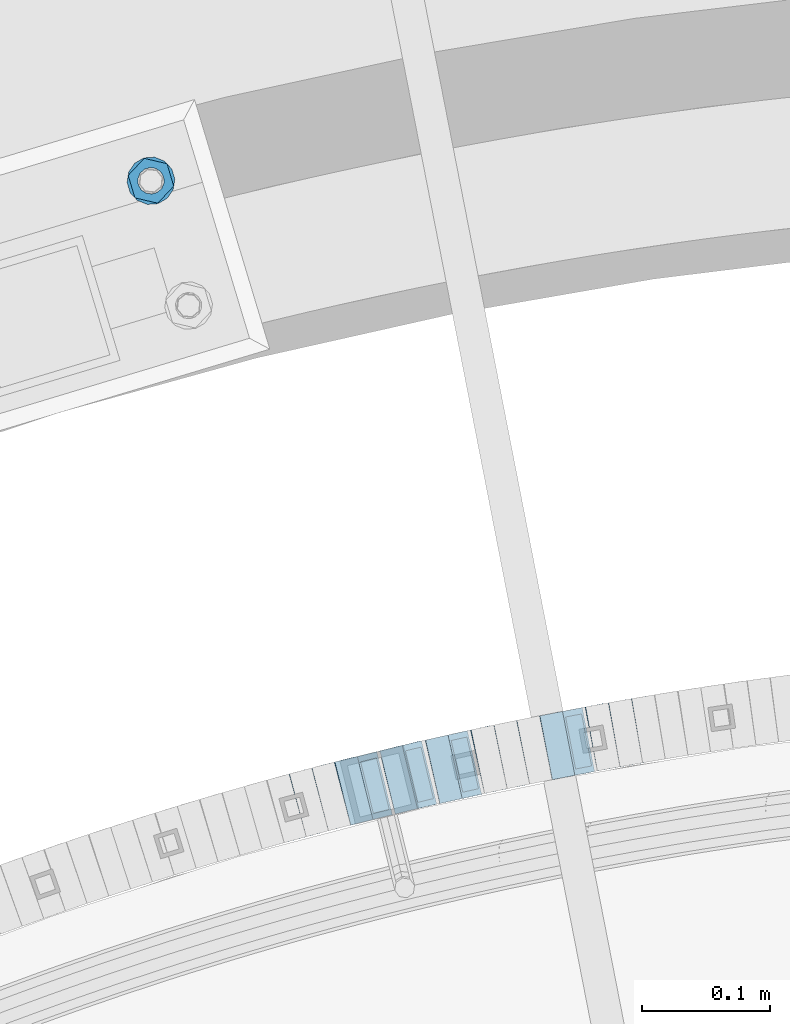
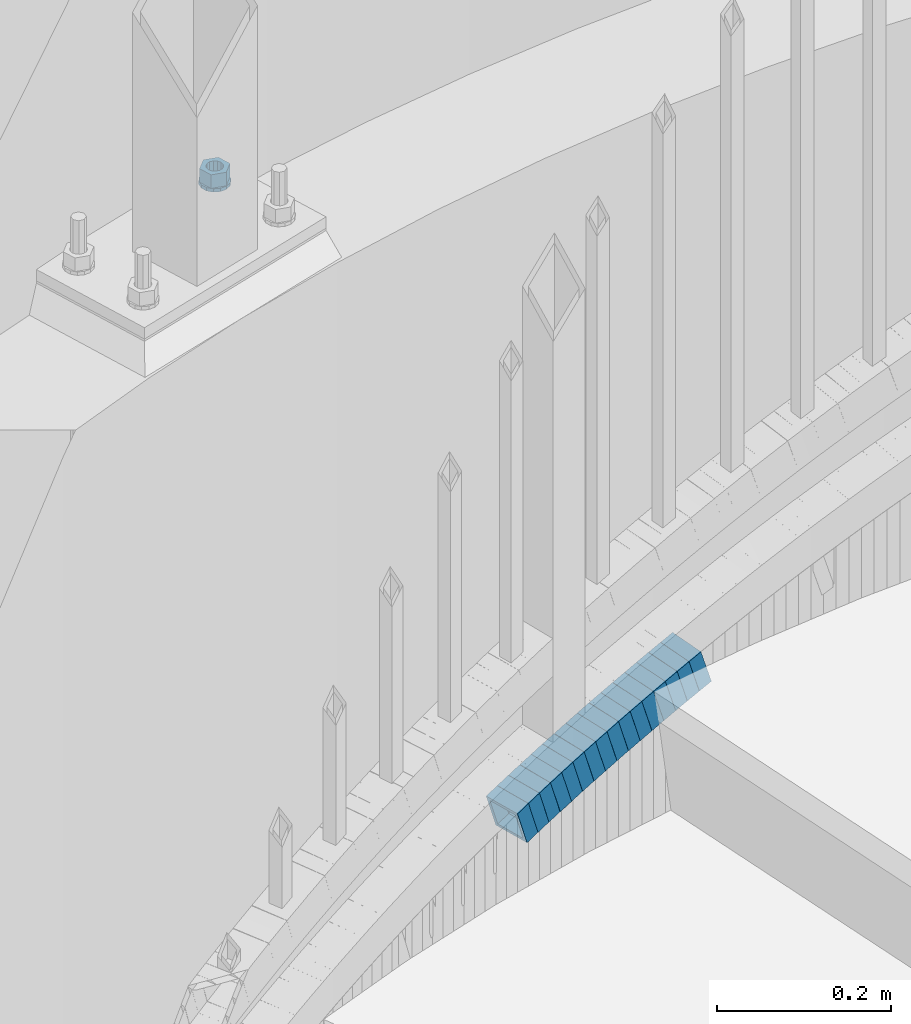
# One storey, part 818 of 975: 18 beams.
"""IFC2X3 building model written with IfcOpenShell, lengths in millimetres."""

from ifc_helpers import new_model, si_unit, frame, origin_with_axes, place, context, subcontext, project, spatial, faceted_brep, material, type_object, element, save


model = new_model("IFC2X3")

# Units and contexts
model_context = context("Model", 3, precision=1e-05, world=origin_with_axes())
body_context = subcontext(model_context, "Body", "Model", "MODEL_VIEW")
ifc_project = project(units=[si_unit("LENGTHUNIT", "METRE", prefix="MILLI"), si_unit("AREAUNIT", "SQUARE_METRE"), si_unit("VOLUMEUNIT", "CUBIC_METRE"), si_unit("MASSUNIT", "GRAM", prefix="KILO"), si_unit("TIMEUNIT", "SECOND"), si_unit("PLANEANGLEUNIT", "RADIAN"), si_unit("SOLIDANGLEUNIT", "STERADIAN"), si_unit("THERMODYNAMICTEMPERATUREUNIT", "DEGREE_CELSIUS"), si_unit("LUMINOUSINTENSITYUNIT", "LUMEN")], contexts=[model_context])

# Site, building, storey
site_placement = place(None, origin_with_axes())
site = spatial("IfcSite", under=ifc_project, at=site_placement, CompositionType="ELEMENT")
building_placement = place(site_placement, origin_with_axes())
building = spatial("IfcBuilding", under=site, at=building_placement, Name="Undefined", CompositionType="ELEMENT")
storey_placement = place(building_placement, origin_with_axes())
storey = spatial("IfcBuildingStorey", under=building, at=storey_placement, Name="Undefined", CompositionType="ELEMENT", Elevation=0.0)

# Beams
ifc_material_1 = material()
beam_type_1 = type_object("IfcBeamType", Name="HSS2X2X.188_TUBES", PredefinedType="NOTDEFINED")
beam_1_placement = place(storey_placement, frame((34239.5189217733, 6231.2273119893, 881.998888909434), z_axis=(0.178885438594422, -0.983869910028191, -3.6949131754227e-10), x_axis=(-0.93743090566095, -0.170441982938337, -0.303599781890138)))
element("IfcBeam", 1, at=beam_1_placement, inside=storey, type_object=beam_type_1, material=ifc_material_1, Name="WALL", ObjectType="HSS2X2X.188_TUBES", context=body_context, shape_type="Brep", body=[
    faceted_brep([(0.0, 20.6374999999753, -20.6375000000298), (0.0, -20.6375000000153, -20.6375000000153), (18.767258723612, -20.6375000000025, -20.6374999999862), (18.7672587236229, 20.6374999999953, -20.637499999968), (0.0, -20.6374999999825, 20.6375000000335), (18.767258723612, -20.6375000000135, 20.6375000000153), (0.0, 20.6375000000116, 20.6375000000189), (18.7672587236266, 20.6374999999844, 20.6375000000371), (0.0, 25.3999999999724, -25.4000000000342), (0.0, 25.400000000016, 25.4000000000196), (18.7672587236302, 25.3999999999814, 25.4000000000342), (18.7672587236229, 25.399999999996, -25.3999999999687), (0.0, -25.399999999976, 25.4000000000378), (18.7672587236157, -25.4000000000142, 25.400000000016), (0.0, -25.400000000016, -25.4000000000196), (18.767258723612, -25.4000000000015, -25.3999999999905)], [[[0, 1, 2, 3]], [[1, 4, 5, 2]], [[4, 6, 7, 5]], [[6, 0, 3, 7]], [[8, 9, 10, 11]], [[9, 12, 13, 10]], [[12, 14, 15, 13]], [[14, 8, 11, 15]], [[13, 15, 11, 10], [5, 7, 3, 2]], [[14, 12, 9, 8], [6, 4, 1, 0]]]),
])
beam_2_placement = place(storey_placement, frame((34257.4787266517, 6234.3226961363, 887.827943046003), z_axis=(0.172515321608458, -0.985006834397777, 1.71298665918584e-10), x_axis=(-0.937387453226914, -0.164175204039738, -0.307166510074373)))
element("IfcBeam", 2, at=beam_2_placement, inside=storey, type_object=beam_type_1, material=ifc_material_1, Name="WALL", ObjectType="HSS2X2X.188_TUBES", context=body_context, shape_type="Brep", body=[
    faceted_brep([(0.0, 20.6374999999753, -20.6375000000298), (0.0, -20.6375000000153, -20.6375000000153), (18.8814724002259, -20.6375000000171, -20.6374999999753), (18.8814724002277, 20.6374999999916, -20.6374999999716), (0.0, -20.6374999999825, 20.6375000000335), (18.8814724002368, -20.6375000000062, 20.6375000000298), (0.0, 20.6375000000116, 20.6375000000189), (18.8814724002386, 20.6375000000025, 20.6375000000262), (0.0, 25.3999999999724, -25.4000000000342), (0.0, 25.400000000016, 25.4000000000196), (18.8814724002386, 25.4000000000051, 25.4000000000269), (18.8814724002277, 25.3999999999905, -25.399999999976), (0.0, -25.399999999976, 25.4000000000378), (18.8814724002368, -25.4000000000051, 25.4000000000269), (0.0, -25.400000000016, -25.4000000000196), (18.8814724002259, -25.4000000000196, -25.399999999976)], [[[0, 1, 2, 3]], [[1, 4, 5, 2]], [[4, 6, 7, 5]], [[6, 0, 3, 7]], [[8, 9, 10, 11]], [[9, 12, 13, 10]], [[12, 14, 15, 13]], [[14, 8, 11, 15]], [[13, 15, 11, 10], [5, 7, 3, 2]], [[14, 12, 9, 8], [6, 4, 1, 0]]]),
])
beam_3_placement = place(storey_placement, frame((34221.6151304327, 6228.05640021302, 876.294305720647), z_axis=(0.189674976082606, -0.981846934836618, -7.12880137143657e-11), x_axis=(-0.935680580477902, -0.180756476092345, -0.303032915154796)))
element("IfcBeam", 3, at=beam_3_placement, inside=storey, type_object=beam_type_1, material=ifc_material_1, Name="WALL", ObjectType="HSS2X2X.188_TUBES", context=body_context, shape_type="Brep", body=[
    faceted_brep([(0.0, 20.6374999999753, -20.6375000000298), (0.0, -20.6375000000153, -20.6375000000153), (18.8066477608099, -20.6374999999862, -20.6375000000116), (18.8066477608172, 20.6375000000062, -20.6374999999971), (0.0, -20.6374999999825, 20.6375000000335), (18.8066477608463, -20.6375000000062, 20.6375000000407), (0.0, 20.6375000000116, 20.6375000000189), (18.8066477608536, 20.6374999999844, 20.637500000048), (0.0, 25.3999999999724, -25.4000000000342), (0.0, 25.400000000016, 25.4000000000196), (18.8066477608591, 25.3999999999814, 25.400000000056), (18.8066477608154, 25.4000000000051, -25.4000000000015), (0.0, -25.399999999976, 25.4000000000378), (18.8066477608518, -25.4000000000087, 25.4000000000451), (0.0, -25.400000000016, -25.4000000000196), (18.8066477608081, -25.3999999999851, -25.4000000000196)], [[[0, 1, 2, 3]], [[1, 4, 5, 2]], [[4, 6, 7, 5]], [[6, 0, 3, 7]], [[8, 9, 10, 11]], [[9, 12, 13, 10]], [[12, 14, 15, 13]], [[14, 8, 11, 15]], [[13, 15, 11, 10], [5, 7, 3, 2]], [[14, 12, 9, 8], [6, 4, 1, 0]]]),
])
beam_4_placement = place(storey_placement, frame((34186.3831927478, 6221.29337589395, 864.83109418146), z_axis=(0.195044345916496, -0.980794424497818, 5.18537035532062e-12), x_axis=(-0.933257011147274, -0.185590883029333, -0.307550606048581)))
element("IfcBeam", 4, at=beam_4_placement, inside=storey, type_object=beam_type_1, material=ifc_material_1, Name="WALL", ObjectType="HSS2X2X.188_TUBES", context=body_context, shape_type="Brep", body=[
    faceted_brep([(0.0, 20.6374999999753, -20.6375000000298), (0.0, -20.6375000000153, -20.6375000000153), (18.8565638439322, -20.6375000000116, -20.6374999999643), (18.8565638439395, 20.637499999988, -20.6374999999534), (0.0, -20.6374999999825, 20.6375000000335), (18.856563843914, -20.6374999999953, 20.6375000000116), (0.0, 20.6375000000116, 20.6375000000189), (18.8565638439177, 20.6375000000007, 20.6375000000226), (0.0, 25.3999999999724, -25.4000000000342), (0.0, 25.400000000016, 25.4000000000196), (18.8565638439177, 25.4000000000033, 25.4000000000233), (18.8565638439468, 25.3999999999851, -25.3999999999505), (0.0, -25.399999999976, 25.4000000000378), (18.8565638439104, -25.399999999996, 25.4000000000087), (0.0, -25.400000000016, -25.4000000000196), (18.8565638439395, -25.4000000000124, -25.3999999999614)], [[[0, 1, 2, 3]], [[1, 4, 5, 2]], [[4, 6, 7, 5]], [[6, 0, 3, 7]], [[8, 9, 10, 11]], [[9, 12, 13, 10]], [[12, 14, 15, 13]], [[14, 8, 11, 15]], [[13, 15, 11, 10], [5, 7, 3, 2]], [[14, 12, 9, 8], [6, 4, 1, 0]]]),
])
beam_5_placement = place(storey_placement, frame((34204.1352478787, 6224.67960458725, 870.633548214716), z_axis=(0.189674976082606, -0.981846934836618, -7.12880137143657e-11), x_axis=(-0.934163649520501, -0.180463415907332, -0.307849364841956)))
element("IfcBeam", 5, at=beam_5_placement, inside=storey, type_object=beam_type_1, material=ifc_material_1, Name="WALL", ObjectType="HSS2X2X.188_TUBES", context=body_context, shape_type="Brep", body=[
    faceted_brep([(0.0, 20.6374999999753, -20.6375000000298), (0.0, -20.6375000000153, -20.6375000000153), (18.8433011969464, -20.6374999999898, -20.6375000000226), (18.8433011969719, 20.6375000000007, -20.6374999999862), (0.0, -20.6374999999825, 20.6375000000335), (18.8433011969828, -20.6375000000044, 20.6375000000189), (0.0, 20.6375000000116, 20.6375000000189), (18.8433011970155, 20.6374999999862, 20.6375000000517), (0.0, 25.3999999999724, -25.4000000000342), (0.0, 25.400000000016, 25.4000000000196), (18.8433011970228, 25.3999999999833, 25.4000000000597), (18.8433011969719, 25.4000000000015, -25.3999999999869), (0.0, -25.399999999976, 25.4000000000378), (18.8433011969864, -25.4000000000051, 25.4000000000196), (0.0, -25.400000000016, -25.4000000000196), (18.8433011969391, -25.3999999999869, -25.4000000000269)], [[[0, 1, 2, 3]], [[1, 4, 5, 2]], [[4, 6, 7, 5]], [[6, 0, 3, 7]], [[8, 9, 10, 11]], [[9, 12, 13, 10]], [[12, 14, 15, 13]], [[14, 8, 11, 15]], [[13, 15, 11, 10], [5, 7, 3, 2]], [[14, 12, 9, 8], [6, 4, 1, 0]]]),
])
beam_6_placement = place(storey_placement, frame((34150.8598307593, 6214.19298295181, 853.28698360437), z_axis=(0.20573024626261, -0.978608739881637, 8.91679974301951e-11), x_axis=(-0.932876750915599, -0.196116134982284, -0.302124856972687)))
element("IfcBeam", 6, at=beam_6_placement, inside=storey, type_object=beam_type_1, material=ifc_material_1, Name="WALL", ObjectType="HSS2X2X.188_TUBES", context=body_context, shape_type="Brep", body=[
    faceted_brep([(0.0, 20.6374999999753, -20.6375000000298), (0.0, -20.6375000000153, -20.6375000000153), (18.8653120832787, -20.6374999999989, -20.6374999999935), (18.8653120832823, 20.6374999999971, -20.6374999999935), (0.0, -20.6374999999825, 20.6375000000335), (18.8653120833151, -20.6375000000116, 20.6375000000298), (0.0, 20.6375000000116, 20.6375000000189), (18.8653120833151, 20.6374999999844, 20.6375000000298), (0.0, 25.3999999999724, -25.4000000000342), (0.0, 25.400000000016, 25.4000000000196), (18.8653120833187, 25.3999999999814, 25.4000000000378), (18.8653120832823, 25.3999999999942, -25.3999999999905), (0.0, -25.399999999976, 25.4000000000378), (18.8653120833187, -25.4000000000124, 25.4000000000342), (0.0, -25.400000000016, -25.4000000000196), (18.8653120832787, -25.3999999999978, -25.3999999999942)], [[[0, 1, 2, 3]], [[1, 4, 5, 2]], [[4, 6, 7, 5]], [[6, 0, 3, 7]], [[8, 9, 10, 11]], [[9, 12, 13, 10]], [[12, 14, 15, 13]], [[14, 8, 11, 15]], [[13, 15, 11, 10], [5, 7, 3, 2]], [[14, 12, 9, 8], [6, 4, 1, 0]]]),
])
beam_7_placement = place(storey_placement, frame((34168.5193386462, 6217.79214693739, 859.00164875351), z_axis=(0.201494991791857, -0.979489544754205, -4.92411800223636e-11), x_axis=(-0.933150868224817, -0.191962464046253, -0.303940569073234)))
element("IfcBeam", 7, at=beam_7_placement, inside=storey, type_object=beam_type_1, material=ifc_material_1, Name="WALL", ObjectType="HSS2X2X.188_TUBES", context=body_context, shape_type="Brep", body=[
    faceted_brep([(0.0, 20.6374999999753, -20.6375000000298), (0.0, -20.6375000000153, -20.6375000000153), (18.7547327359644, -20.6374999999844, -20.6375000000553), (18.7547327359898, 20.6375000000171, -20.6375000000335), (0.0, -20.6374999999825, 20.6375000000335), (18.7547327360044, -20.6374999999953, 20.6374999999898), (0.0, 20.6375000000116, 20.6375000000189), (18.7547327360262, 20.6375000000062, 20.6375000000116), (0.0, 25.3999999999724, -25.4000000000342), (0.0, 25.400000000016, 25.4000000000196), (18.7547327360371, 25.4000000000033, 25.4000000000124), (18.7547327359898, 25.4000000000178, -25.4000000000342), (0.0, -25.399999999976, 25.4000000000378), (18.7547327360044, -25.399999999996, 25.3999999999869), (0.0, -25.400000000016, -25.4000000000196), (18.7547327359498, -25.3999999999814, -25.4000000000597)], [[[0, 1, 2, 3]], [[1, 4, 5, 2]], [[4, 6, 7, 5]], [[6, 0, 3, 7]], [[8, 9, 10, 11]], [[9, 12, 13, 10]], [[12, 14, 15, 13]], [[14, 8, 11, 15]], [[13, 15, 11, 10], [5, 7, 3, 2]], [[14, 12, 9, 8], [6, 4, 1, 0]]]),
])
beam_8_placement = place(storey_placement, frame((34115.4667915675, 6206.63406486853, 841.806006393488), z_axis=(0.218711456909339, -0.975789577017809, -2.95224253932247e-11), x_axis=(-0.929458535361811, -0.208326913081082, -0.304477796118511)))
element("IfcBeam", 8, at=beam_8_placement, inside=storey, type_object=beam_type_1, material=ifc_material_1, Name="WALL", ObjectType="HSS2X2X.188_TUBES", context=body_context, shape_type="Brep", body=[
    faceted_brep([(0.0, 20.6374999999753, -20.6375000000298), (0.0, -20.6375000000153, -20.6375000000153), (18.724849799155, -20.6375000000171, -20.6374999999425), (18.7248497991204, 20.6374999999989, -20.6375000000007), (0.0, -20.6374999999825, 20.6375000000335), (18.7248497991168, -20.6374999999953, 20.6375000000007), (0.0, 20.6375000000116, 20.6375000000189), (18.724849799084, 20.6375000000226, 20.6374999999498), (0.0, 25.3999999999724, -25.4000000000342), (0.0, 25.400000000016, 25.4000000000196), (18.7248497990731, 25.4000000000269, 25.399999999936), (18.7248497991204, 25.3999999999978, -25.3999999999978), (0.0, -25.399999999976, 25.4000000000378), (18.7248497991186, -25.3999999999942, 25.4000000000051), (0.0, -25.400000000016, -25.4000000000196), (18.7248497991604, -25.4000000000233, -25.3999999999323)], [[[0, 1, 2, 3]], [[1, 4, 5, 2]], [[4, 6, 7, 5]], [[6, 0, 3, 7]], [[8, 9, 10, 11]], [[9, 12, 13, 10]], [[12, 14, 15, 13]], [[14, 8, 11, 15]], [[13, 15, 11, 10], [5, 7, 3, 2]], [[14, 12, 9, 8], [6, 4, 1, 0]]]),
])
beam_9_placement = place(storey_placement, frame((34133.0811706486, 6210.54990895885, 847.633049615749), z_axis=(0.217520973168837, -0.976055647097891, 4.64212916995165e-11), x_axis=(-0.928672771956781, -0.206961360990381, -0.307788689985708)))
element("IfcBeam", 9, at=beam_9_placement, inside=storey, type_object=beam_type_1, material=ifc_material_1, Name="WALL", ObjectType="HSS2X2X.188_TUBES", context=body_context, shape_type="Brep", body=[
    faceted_brep([(0.0, 20.6374999999753, -20.6375000000298), (0.0, -20.6375000000153, -20.6375000000153), (18.8433011969464, -20.6374999999898, -20.6375000000226), (18.8433011969719, 20.6375000000007, -20.6374999999862), (0.0, -20.6374999999825, 20.6375000000335), (18.8433011969828, -20.6375000000044, 20.6375000000189), (0.0, 20.6375000000116, 20.6375000000189), (18.8433011970155, 20.6374999999862, 20.6375000000517), (0.0, 25.3999999999724, -25.4000000000342), (0.0, 25.400000000016, 25.4000000000196), (18.8433011970228, 25.3999999999833, 25.4000000000597), (18.8433011969719, 25.4000000000015, -25.3999999999869), (0.0, -25.399999999976, 25.4000000000378), (18.8433011969864, -25.4000000000051, 25.4000000000196), (0.0, -25.400000000016, -25.4000000000196), (18.8433011969391, -25.3999999999869, -25.4000000000269)], [[[0, 1, 2, 3]], [[1, 4, 5, 2]], [[4, 6, 7, 5]], [[6, 0, 3, 7]], [[8, 9, 10, 11]], [[9, 12, 13, 10]], [[12, 14, 15, 13]], [[14, 8, 11, 15]], [[13, 15, 11, 10], [5, 7, 3, 2]], [[14, 12, 9, 8], [6, 4, 1, 0]]]),
])
beam_10_placement = place(storey_placement, frame((34098.0286308451, 6202.75903151659, 836.130242844753), z_axis=(0.222824801331393, -0.974858506610895, -1.82580492946727e-10), x_axis=(-0.927641471385163, -0.212032336088062, -0.307446888127704)))
element("IfcBeam", 10, at=beam_10_placement, inside=storey, type_object=beam_type_1, material=ifc_material_1, Name="WALL", ObjectType="HSS2X2X.188_TUBES", context=body_context, shape_type="Brep", body=[
    faceted_brep([(0.0, 20.6374999999753, -20.6375000000298), (0.0, -20.6375000000153, -20.6375000000153), (18.8653120832787, -20.6374999999989, -20.6374999999935), (18.8653120832823, 20.6374999999971, -20.6374999999935), (0.0, -20.6374999999825, 20.6375000000335), (18.8653120833151, -20.6375000000116, 20.6375000000298), (0.0, 20.6375000000116, 20.6375000000189), (18.8653120833151, 20.6374999999844, 20.6375000000298), (0.0, 25.3999999999724, -25.4000000000342), (0.0, 25.400000000016, 25.4000000000196), (18.8653120833187, 25.3999999999814, 25.4000000000378), (18.8653120832823, 25.3999999999942, -25.3999999999905), (0.0, -25.399999999976, 25.4000000000378), (18.8653120833187, -25.4000000000124, 25.4000000000342), (0.0, -25.400000000016, -25.4000000000196), (18.8653120832787, -25.3999999999978, -25.3999999999942)], [[[0, 1, 2, 3]], [[1, 4, 5, 2]], [[4, 6, 7, 5]], [[6, 0, 3, 7]], [[8, 9, 10, 11]], [[9, 12, 13, 10]], [[12, 14, 15, 13]], [[14, 8, 11, 15]], [[13, 15, 11, 10], [5, 7, 3, 2]], [[14, 12, 9, 8], [6, 4, 1, 0]]]),
])
beam_11_placement = place(storey_placement, frame((34080.107592637, 6198.75683035603, 830.297496352018), z_axis=(0.234640533210106, -0.97208220854765, 9.88381998467958e-11), x_axis=(-0.926252882322652, -0.2235782820779, -0.303427668105719)))
element("IfcBeam", 11, at=beam_11_placement, inside=storey, type_object=beam_type_1, material=ifc_material_1, Name="WALL", ObjectType="HSS2X2X.188_TUBES", context=body_context, shape_type="Brep", body=[
    faceted_brep([(0.0, 20.6374999999753, -20.6375000000298), (0.0, -20.6375000000153, -20.6375000000153), (18.7853666454903, -20.6375000000535, -20.6375000000326), (18.785366645363, 20.6374999999862, -20.6375000000044), (0.0, -20.6374999999825, 20.6375000000335), (18.785366645352, -20.6375000000007, 20.6374999999989), (0.0, 20.6375000000116, 20.6375000000189), (18.7853666453102, 20.6375000000025, 20.6374999999753), (0.0, 25.3999999999724, -25.4000000000342), (0.0, 25.400000000016, 25.4000000000196), (18.7853666452065, 25.4000000000451, 25.4000000000351), (18.7853666453739, 25.3999999999833, -25.400000000006), (0.0, -25.399999999976, 25.4000000000378), (18.7853666497213, -25.399999993424, 25.3999999995158), (0.0, -25.400000000016, -25.4000000000196), (18.7853666455194, -25.4000000000633, -25.4000000000406)], [[[0, 1, 2, 3]], [[1, 4, 5, 2]], [[4, 6, 7, 5]], [[6, 0, 3, 7]], [[8, 9, 10, 11]], [[9, 12, 13, 10]], [[12, 14, 15, 13]], [[14, 8, 11, 15]], [[13, 15, 11, 10], [5, 7, 3, 2]], [[14, 12, 9, 8], [6, 4, 1, 0]]]),
])
beam_12_placement = place(storey_placement, frame((34062.55609674, 6194.57353386894, 824.606676892069), z_axis=(0.241215480087354, -0.970471582358921, -5.75937519897707e-13), x_axis=(-0.924367424052871, -0.229756065013127, -0.304560365017418)))
element("IfcBeam", 12, at=beam_12_placement, inside=storey, type_object=beam_type_1, material=ifc_material_1, Name="WALL", ObjectType="HSS2X2X.188_TUBES", context=body_context, shape_type="Brep", body=[
    faceted_brep([(0.0, 20.6374999999753, -20.6375000000298), (0.0, -20.6375000000153, -20.6375000000153), (18.724849799155, -20.6375000000171, -20.6374999999425), (18.7248497991204, 20.6374999999989, -20.6375000000007), (0.0, -20.6374999999825, 20.6375000000335), (18.7248497991168, -20.6374999999953, 20.6375000000007), (0.0, 20.6375000000116, 20.6375000000189), (18.724849799084, 20.6375000000226, 20.6374999999498), (0.0, 25.3999999999724, -25.4000000000342), (0.0, 25.400000000016, 25.4000000000196), (18.7248497990731, 25.4000000000269, 25.399999999936), (18.7248497991204, 25.3999999999978, -25.3999999999978), (0.0, -25.399999999976, 25.4000000000378), (18.7248497991186, -25.3999999999942, 25.4000000000051), (0.0, -25.400000000016, -25.4000000000196), (18.7248497991604, -25.4000000000233, -25.3999999999323)], [[[0, 1, 2, 3]], [[1, 4, 5, 2]], [[4, 6, 7, 5]], [[6, 0, 3, 7]], [[8, 9, 10, 11]], [[9, 12, 13, 10]], [[12, 14, 15, 13]], [[14, 8, 11, 15]], [[13, 15, 11, 10], [5, 7, 3, 2]], [[14, 12, 9, 8], [6, 4, 1, 0]]]),
])
beam_13_placement = place(storey_placement, frame((34045.3736307885, 6190.29187918018, 818.933797876978), z_axis=(0.239909191617488, -0.970795333619524, -9.06261448108126e-11), x_axis=(-0.923639222967925, -0.228255669992112, -0.307879740989335)))
element("IfcBeam", 13, at=beam_13_placement, inside=storey, type_object=beam_type_1, material=ifc_material_1, Name="WALL", ObjectType="HSS2X2X.188_TUBES", context=body_context, shape_type="Brep", body=[
    faceted_brep([(0.0, 20.6374999999753, -20.6375000000298), (0.0, -20.6375000000153, -20.6375000000153), (18.8433011969464, -20.6374999999898, -20.6375000000226), (18.8433011969719, 20.6375000000007, -20.6374999999862), (0.0, -20.6374999999825, 20.6375000000335), (18.8433011969828, -20.6375000000044, 20.6375000000189), (0.0, 20.6375000000116, 20.6375000000189), (18.8433011970155, 20.6374999999862, 20.6375000000517), (0.0, 25.3999999999724, -25.4000000000342), (0.0, 25.400000000016, 25.4000000000196), (18.8433011970228, 25.3999999999833, 25.4000000000597), (18.8433011969719, 25.4000000000015, -25.3999999999869), (0.0, -25.399999999976, 25.4000000000378), (18.8433011969864, -25.4000000000051, 25.4000000000196), (0.0, -25.400000000016, -25.4000000000196), (18.8433011969391, -25.3999999999869, -25.4000000000269)], [[[0, 1, 2, 3]], [[1, 4, 5, 2]], [[4, 6, 7, 5]], [[6, 0, 3, 7]], [[8, 9, 10, 11]], [[9, 12, 13, 10]], [[12, 14, 15, 13]], [[14, 8, 11, 15]], [[13, 15, 11, 10], [5, 7, 3, 2]], [[14, 12, 9, 8], [6, 4, 1, 0]]]),
])
beam_14_placement = place(storey_placement, frame((34027.5493659819, 6185.98208639023, 813.100494362804), z_axis=(0.251738650051681, -0.967795253176083, 1.81512405106332e-12), x_axis=(-0.922053806967874, -0.239840585991619, -0.303798074989371)))
element("IfcBeam", 14, at=beam_14_placement, inside=storey, type_object=beam_type_1, material=ifc_material_1, Name="WALL", ObjectType="HSS2X2X.188_TUBES", context=body_context, shape_type="Brep", body=[
    faceted_brep([(0.0, 20.6374999999753, -20.6375000000298), (0.0, -20.6375000000153, -20.6375000000153), (18.7555325170906, -20.6374999999916, -20.6374999999971), (18.7555325171452, 20.637499999988, -20.6374999999571), (0.0, -20.6374999999825, 20.6375000000335), (18.7555325170615, -20.6374999999844, 20.6374999999716), (0.0, 20.6375000000116, 20.6375000000189), (18.7555325171015, 20.6374999999953, 20.637500000008), (0.0, 25.3999999999724, -25.4000000000342), (0.0, 25.400000000016, 25.4000000000196), (18.7555325171015, 25.399999999996, 25.4000000000051), (18.7555325171488, 25.3999999999851, -25.3999999999505), (0.0, -25.399999999976, 25.4000000000378), (18.755532517047, -25.3999999999814, 25.3999999999578), (0.0, -25.400000000016, -25.4000000000196), (18.7555325170979, -25.3999999999924, -25.3999999999978)], [[[0, 1, 2, 3]], [[1, 4, 5, 2]], [[4, 6, 7, 5]], [[6, 0, 3, 7]], [[8, 9, 10, 11]], [[9, 12, 13, 10]], [[12, 14, 15, 13]], [[14, 8, 11, 15]], [[13, 15, 11, 10], [5, 7, 3, 2]], [[14, 12, 9, 8], [6, 4, 1, 0]]]),
])
beam_15_placement = place(storey_placement, frame((34010.0946983078, 6181.49605076979, 807.409437300346), z_axis=(0.258361740298409, -0.966048244732103, -2.28899807552807e-10), x_axis=(-0.920049238166293, -0.24605968004449, -0.304900038055142)))
element("IfcBeam", 15, at=beam_15_placement, inside=storey, type_object=beam_type_1, material=ifc_material_1, Name="WALL", ObjectType="HSS2X2X.188_TUBES", context=body_context, shape_type="Brep", body=[
    faceted_brep([(0.0, 20.6374999999753, -20.6375000000298), (0.0, -20.6375000000153, -20.6375000000153), (18.6895692834223, -20.637499999988, -20.6374999999862), (18.6895692834369, 20.6374999999953, -20.6374999999534), (0.0, -20.6374999999825, 20.6375000000335), (18.6895692833914, -20.637499999988, 20.6374999999789), (0.0, 20.6375000000116, 20.6375000000189), (18.6895692834078, 20.6374999999953, 20.637500000008), (0.0, 25.3999999999724, -25.4000000000342), (0.0, 25.400000000016, 25.4000000000196), (18.6895692834059, 25.3999999999924, 25.4000000000087), (18.6895692834423, 25.3999999999942, -25.3999999999432), (0.0, -25.399999999976, 25.4000000000378), (18.6895692833878, -25.3999999999869, 25.3999999999687), (0.0, -25.400000000016, -25.4000000000196), (18.6895692834241, -25.3999999999869, -25.3999999999833)], [[[0, 1, 2, 3]], [[1, 4, 5, 2]], [[4, 6, 7, 5]], [[6, 0, 3, 7]], [[8, 9, 10, 11]], [[9, 12, 13, 10]], [[12, 14, 15, 13]], [[14, 8, 11, 15]], [[13, 15, 11, 10], [5, 7, 3, 2]], [[14, 12, 9, 8], [6, 4, 1, 0]]]),
])
beam_16_placement = place(storey_placement, frame((33992.8615834187, 6176.91893938396, 801.733334560722), z_axis=(0.262173284244702, -0.965020812743615, 9.81468701866106e-11), x_axis=(-0.918162800504632, -0.249443072865388, -0.307823366833912)))
element("IfcBeam", 16, at=beam_16_placement, inside=storey, type_object=beam_type_1, material=ifc_material_1, Name="WALL", ObjectType="HSS2X2X.188_TUBES", context=body_context, shape_type="Brep", body=[
    faceted_brep([(0.0, 20.6374999999753, -20.6375000000298), (0.0, -20.6375000000153, -20.6375000000153), (18.8433011969464, -20.6374999999898, -20.6375000000226), (18.8433011969719, 20.6375000000007, -20.6374999999862), (0.0, -20.6374999999825, 20.6375000000335), (18.8433011969828, -20.6375000000044, 20.6375000000189), (0.0, 20.6375000000116, 20.6375000000189), (18.8433011970155, 20.6374999999862, 20.6375000000517), (0.0, 25.3999999999724, -25.4000000000342), (0.0, 25.400000000016, 25.4000000000196), (18.8433011970228, 25.3999999999833, 25.4000000000597), (18.8433011969719, 25.4000000000015, -25.3999999999869), (0.0, -25.399999999976, 25.4000000000378), (18.8433011969864, -25.4000000000051, 25.4000000000196), (0.0, -25.400000000016, -25.4000000000196), (18.8433011969391, -25.3999999999869, -25.4000000000269)], [[[0, 1, 2, 3]], [[1, 4, 5, 2]], [[4, 6, 7, 5]], [[6, 0, 3, 7]], [[8, 9, 10, 11]], [[9, 12, 13, 10]], [[12, 14, 15, 13]], [[14, 8, 11, 15]], [[13, 15, 11, 10], [5, 7, 3, 2]], [[14, 12, 9, 8], [6, 4, 1, 0]]]),
])
ifc_material_2 = material(Name="STEEL/A36")
beam_type_2 = type_object("IfcBeamType", Name="3/4_WASHER", PredefinedType="NOTDEFINED")
beam_17_placement = place(storey_placement, frame((33870.8360600783, 6661.68538018609, 1433.5125), z_axis=(-0.957369928409554, -0.288864709123642, 0.0), x_axis=(0.0, 0.0, -1.0)))
element("IfcBeam", 17, at=beam_17_placement, inside=storey, type_object=beam_type_2, material=ifc_material_2, Name="WASHER", ObjectType="3/4_WASHER", context=body_context, shape_type="Brep", body=[
    faceted_brep([(0.0, -18.6499996185303, 0.0), (0.0, -16.8030690426876, -8.09193156902904), (4.76250000000073, -16.8030690426876, -8.09193156902904), (4.76250000000073, -18.6499996185303, 0.0), (0.0, -11.6280845668225, -14.5811568497838), (4.76250000000073, -11.6280845668225, -14.5811568497838), (0.0, -4.15001533340001, -18.1824051902857), (4.76250000000073, -4.15001533340001, -18.1824051902857), (0.0, 4.15001533340001, -18.1824051902857), (4.76250000000073, 4.15001533340001, -18.1824051902857), (0.0, 11.6280845668234, -14.5811568497838), (4.76250000000073, 11.6280845668234, -14.5811568497838), (0.0, 16.8030690426876, -8.09193156902904), (4.76250000000073, 16.8030690426876, -8.09193156902904), (0.0, 18.6499996185303, 0.0), (4.76250000000073, 18.6499996185303, 0.0), (0.0, 16.8030690426876, 8.09193156902904), (4.76250000000073, 16.8030690426876, 8.09193156902904), (0.0, 11.6280845668225, 14.5811568497838), (4.76250000000073, 11.6280845668225, 14.5811568497838), (0.0, 4.15001533340001, 18.1824051902857), (4.76250000000073, 4.15001533340001, 18.1824051902857), (0.0, -4.15001533340001, 18.1824051902857), (4.76250000000073, -4.15001533340001, 18.1824051902857), (0.0, -11.6280845668234, 14.5811568497838), (4.76250000000073, -11.6280845668234, 14.5811568497838), (0.0, -16.8030690426876, 8.09193156902904), (4.76250000000073, -16.8030690426876, 8.09193156902904), (0.0, 0.0, 10.3199996948242), (0.0, 4.47768005528269, 9.29799844179911), (4.76250000000073, 4.47768005528269, 9.29799844179911), (4.76250000000073, 0.0, 10.3199996948242), (0.0, 8.06850066047446, 6.43441456490817), (4.76250000000073, 8.06850066047446, 6.43441456490817), (0.0, 10.0612557561917, 2.29641597052117), (4.76250000000073, 10.0612557561917, 2.29641597052117), (0.0, 10.0612557561917, -2.29641597052117), (4.76250000000073, 10.0612557561917, -2.29641597052117), (0.0, 8.06850066047446, -6.43441456490814), (4.76250000000073, 8.06850066047446, -6.43441456490814), (0.0, 4.47768005528269, -9.29799844179908), (4.76250000000073, 4.47768005528269, -9.29799844179908), (0.0, 0.0, -10.3199996948242), (4.76250000000073, 0.0, -10.3199996948242), (0.0, -4.47768005528269, -9.29799844179911), (4.76250000000073, -4.47768005528269, -9.29799844179911), (0.0, -8.06850066047446, -6.43441456490817), (4.76250000000073, -8.06850066047446, -6.43441456490817), (0.0, -10.0612557561917, -2.29641597052117), (4.76250000000073, -10.0612557561917, -2.29641597052117), (0.0, -10.0612557561917, 2.29641597052117), (4.76250000000073, -10.0612557561917, 2.29641597052117), (0.0, -8.06850066047446, 6.43441456490814), (4.76250000000073, -8.06850066047446, 6.43441456490814), (0.0, -4.47768005528269, 9.29799844179908), (4.76250000000073, -4.47768005528269, 9.29799844179908)], [[[0, 1, 2, 3]], [[1, 4, 5, 2]], [[4, 6, 7, 5]], [[6, 8, 9, 7]], [[8, 10, 11, 9]], [[10, 12, 13, 11]], [[12, 14, 15, 13]], [[14, 16, 17, 15]], [[16, 18, 19, 17]], [[18, 20, 21, 19]], [[20, 22, 23, 21]], [[22, 24, 25, 23]], [[24, 26, 27, 25]], [[26, 0, 3, 27]], [[28, 29, 30, 31]], [[29, 32, 33, 30]], [[32, 34, 35, 33]], [[34, 36, 37, 35]], [[36, 38, 39, 37]], [[38, 40, 41, 39]], [[40, 42, 43, 41]], [[42, 44, 45, 43]], [[44, 46, 47, 45]], [[46, 48, 49, 47]], [[48, 50, 51, 49]], [[50, 52, 53, 51]], [[52, 54, 55, 53]], [[54, 28, 31, 55]], [[5, 7, 9, 11, 13, 15, 17, 19, 21, 23, 25, 27, 3, 2], [33, 35, 37, 39, 41, 43, 45, 47, 49, 51, 53, 55, 31, 30]], [[26, 24, 22, 20, 18, 16, 14, 12, 10, 8, 6, 4, 1, 0], [54, 52, 50, 48, 46, 44, 42, 40, 38, 36, 34, 32, 29, 28]]]),
])
beam_type_3 = type_object("IfcBeamType", Name="3/4_HEAVY_HEX_NUT", PredefinedType="NOTDEFINED")
beam_18_placement = place(storey_placement, frame((33870.8360600783, 6661.68538018609, 1452.5625), z_axis=(-0.957369928409554, -0.288864709123642, 0.0), x_axis=(0.0, 0.0, -1.0)))
element("IfcBeam", 18, at=beam_18_placement, inside=storey, type_object=beam_type_3, material=ifc_material_2, Name="NUT", ObjectType="3/4_HEAVY_HEX_NUT", context=body_context, shape_type="Brep", body=[
    faceted_brep([(0.0, -18.2600002288818, 0.0), (0.0, -9.13000011444092, -15.8100004196167), (19.0499999999993, -9.13000011444092, -15.8100004196167), (19.0499999999993, -18.2600002288818, 0.0), (0.0, 9.13000011444092, -15.8100004196167), (19.0499999999993, 9.13000011444092, -15.8100004196167), (0.0, 18.2600002288818, 0.0), (19.0499999999993, 18.2600002288818, 0.0), (0.0, 9.13000011444092, 15.8100004196167), (19.0499999999993, 9.13000011444092, 15.8100004196167), (0.0, -9.13000011444092, 15.8100004196167), (19.0499999999993, -9.13000011444092, 15.8100004196167), (0.0, 0.0, 10.3199996948242), (0.0, 4.47768005528269, 9.29799844179911), (19.0499999999993, 4.47768005528269, 9.29799844179911), (19.0499999999993, 0.0, 10.3199996948242), (0.0, 8.06850066047446, 6.43441456490817), (19.0499999999993, 8.06850066047446, 6.43441456490817), (0.0, 10.0612557561917, 2.29641597052117), (19.0499999999993, 10.0612557561917, 2.29641597052117), (0.0, 10.0612557561917, -2.29641597052117), (19.0499999999993, 10.0612557561917, -2.29641597052117), (0.0, 8.06850066047446, -6.43441456490814), (19.0499999999993, 8.06850066047446, -6.43441456490814), (0.0, 4.47768005528269, -9.29799844179908), (19.0499999999993, 4.47768005528269, -9.29799844179908), (0.0, 0.0, -10.3199996948242), (19.0499999999993, 0.0, -10.3199996948242), (0.0, -4.47768005528269, -9.29799844179911), (19.0499999999993, -4.47768005528269, -9.29799844179911), (0.0, -8.06850066047446, -6.43441456490817), (19.0499999999993, -8.06850066047446, -6.43441456490817), (0.0, -10.0612557561917, -2.29641597052117), (19.0499999999993, -10.0612557561917, -2.29641597052117), (0.0, -10.0612557561917, 2.29641597052117), (19.0499999999993, -10.0612557561917, 2.29641597052117), (0.0, -8.06850066047446, 6.43441456490814), (19.0499999999993, -8.06850066047446, 6.43441456490814), (0.0, -4.47768005528269, 9.29799844179908), (19.0499999999993, -4.47768005528269, 9.29799844179908)], [[[0, 1, 2, 3]], [[1, 4, 5, 2]], [[4, 6, 7, 5]], [[6, 8, 9, 7]], [[8, 10, 11, 9]], [[10, 0, 3, 11]], [[12, 13, 14, 15]], [[13, 16, 17, 14]], [[16, 18, 19, 17]], [[18, 20, 21, 19]], [[20, 22, 23, 21]], [[22, 24, 25, 23]], [[24, 26, 27, 25]], [[26, 28, 29, 27]], [[28, 30, 31, 29]], [[30, 32, 33, 31]], [[32, 34, 35, 33]], [[34, 36, 37, 35]], [[36, 38, 39, 37]], [[38, 12, 15, 39]], [[5, 7, 9, 11, 3, 2], [17, 19, 21, 23, 25, 27, 29, 31, 33, 35, 37, 39, 15, 14]], [[10, 8, 6, 4, 1, 0], [38, 36, 34, 32, 30, 28, 26, 24, 22, 20, 18, 16, 13, 12]]]),
])

save(model, "model.ifc")
